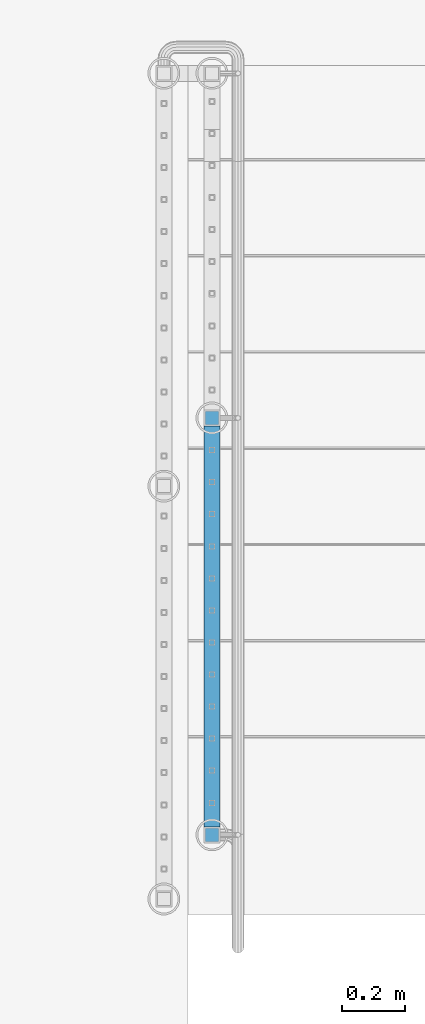
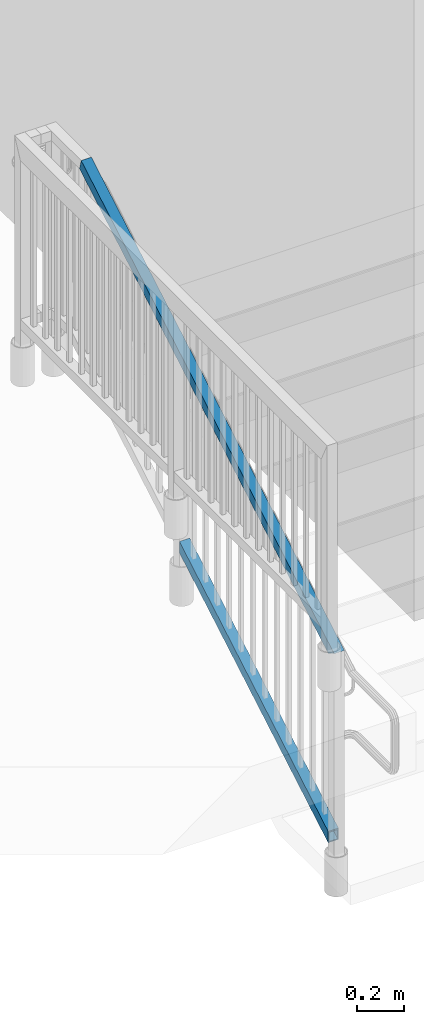
# One storey, part 308 of 975: 2 members.
"""IFC2X3 building model written with IfcOpenShell, lengths in millimetres."""

from ifc_helpers import new_model, si_unit, frame, origin_with_axes, place, context, subcontext, project, spatial, faceted_brep, material, type_object, element, save


model = new_model("IFC2X3")

# Units and contexts
model_context = context("Model", 3, precision=1e-05, world=origin_with_axes())
body_context = subcontext(model_context, "Body", "Model", "MODEL_VIEW")
ifc_project = project(units=[si_unit("LENGTHUNIT", "METRE", prefix="MILLI"), si_unit("AREAUNIT", "SQUARE_METRE"), si_unit("VOLUMEUNIT", "CUBIC_METRE"), si_unit("MASSUNIT", "GRAM", prefix="KILO"), si_unit("TIMEUNIT", "SECOND"), si_unit("PLANEANGLEUNIT", "RADIAN"), si_unit("SOLIDANGLEUNIT", "STERADIAN"), si_unit("THERMODYNAMICTEMPERATUREUNIT", "DEGREE_CELSIUS"), si_unit("LUMINOUSINTENSITYUNIT", "LUMEN")], contexts=[model_context])

# Site, building, storey
site_placement = place(None, origin_with_axes())
site = spatial("IfcSite", under=ifc_project, at=site_placement, CompositionType="ELEMENT")
building_placement = place(site_placement, origin_with_axes())
building = spatial("IfcBuilding", under=site, at=building_placement, Name="Undefined", CompositionType="ELEMENT")
storey_placement = place(building_placement, origin_with_axes())
storey = spatial("IfcBuildingStorey", under=building, at=storey_placement, Name="Undefined", CompositionType="ELEMENT", Elevation=0.0)

# Members
ifc_material = material()
member_type = type_object("IfcMemberType", Name="HSS2X2X.188_TUBES", PredefinedType="NOTDEFINED")
member_1_placement = place(storey_placement, frame((-3190.87499858123, 825.598677503941, 2928.78558603361), z_axis=(-0.999999999999998, 6.90000001668524e-08, 0.0), x_axis=(0.0, 0.863778900717086, 0.503871025834967)))
element("IfcMember", 1, at=member_1_placement, inside=storey, type_object=member_type, material=ifc_material, Name="HANDRAIL", ObjectType="HSS2X2X.188_TUBES", context=body_context, shape_type="Brep", body=[
    faceted_brep([(2.55046412185675, 20.6375000000007, -20.6375000000004), (26.6275483126865, -20.6374999999948, -20.6375000000022), (1496.91121689991, -20.6374999997697, -20.6375000000742), (1472.83413271209, 20.6375000002295, -20.6375000000716), (26.6275482985616, -20.6374999999989, 20.6375000000005), (1496.91121692682, -20.6374999997643, 20.6374999999254), (2.5504641077323, 20.6374999999971, 20.6375000000022), (1472.834132739, 20.6375000002349, 20.6374999999281), (-0.227660975455819, 25.4000000000015, -25.4000000000003), (-0.227660992839446, 25.399999999996, 25.4000000000028), (1470.05600764351, 25.4000000002352, 25.3999999999284), (1470.05600761039, 25.4000000002284, -25.4000000000711), (29.4056733958746, -25.3999999999987, 25.4000000000005), (1499.68934202852, -25.3999999997636, 25.3999999999249), (29.4056734132582, -25.3999999999933, -25.4000000000028), (1499.6893419954, -25.3999999997704, -25.4000000000746)], [[[0, 1, 2, 3]], [[1, 4, 5, 2]], [[4, 6, 7, 5]], [[6, 0, 3, 7]], [[8, 9, 10, 11]], [[9, 12, 13, 10]], [[12, 14, 15, 13]], [[14, 8, 11, 15]], [[13, 15, 11, 10], [5, 7, 3, 2]], [[14, 12, 9, 8], [6, 4, 1, 0]]]),
])
member_2_placement = place(storey_placement, frame((-3190.87499858123, 812.800367800863, 3907.59432681638), z_axis=(-0.999999999999998, 6.90000001668524e-08, 0.0), x_axis=(0.0, 0.863778900717086, 0.503871025834967)))
element("IfcMember", 2, at=member_2_placement, inside=storey, type_object=member_type, material=ifc_material, Name="HANDRAIL", ObjectType="HSS2X2X.188_TUBES", context=body_context, shape_type="Brep", body=[
    faceted_brep([(11.8535676793817, 20.6375000000003, -20.6374999999996), (-11.8535673581096, -20.6375000000062, -20.6375), (2483.60566882406, -20.6374999996169, -20.6375000001226), (2472.44700660959, 20.6375000003854, -20.6375000001206), (-11.8535673311985, -20.6375000000007, 20.6374999999996), (2483.60566883982, -20.6374999996106, 20.6374999998769), (11.8535677062928, 20.6375000000057, 20.6374999999999), (2472.44700662534, 20.6375000003895, 20.6374999998792), (14.5890063344486, 25.4000000000001, -25.3999999999995), (14.5890063675702, 25.4000000000069, 25.4), (2471.15946867934, 25.4000000003916, 25.3999999998792), (2471.15946865995, 25.4000000003853, -25.4000000001204), (-14.5890059862654, -25.400000000001, 25.3999999999995), (2484.89320678946, -25.3999999996104, 25.3999999998767), (-14.5890060193869, -25.4000000000078, -25.4), (2484.89320677007, -25.3999999996167, -25.4000000001228)], [[[0, 1, 2, 3]], [[1, 4, 5, 2]], [[4, 6, 7, 5]], [[6, 0, 3, 7]], [[8, 9, 10, 11]], [[9, 12, 13, 10]], [[12, 14, 15, 13]], [[14, 8, 11, 15]], [[13, 15, 11, 10], [5, 7, 3, 2]], [[14, 12, 9, 8], [6, 4, 1, 0]]]),
])

save(model, "model.ifc")
